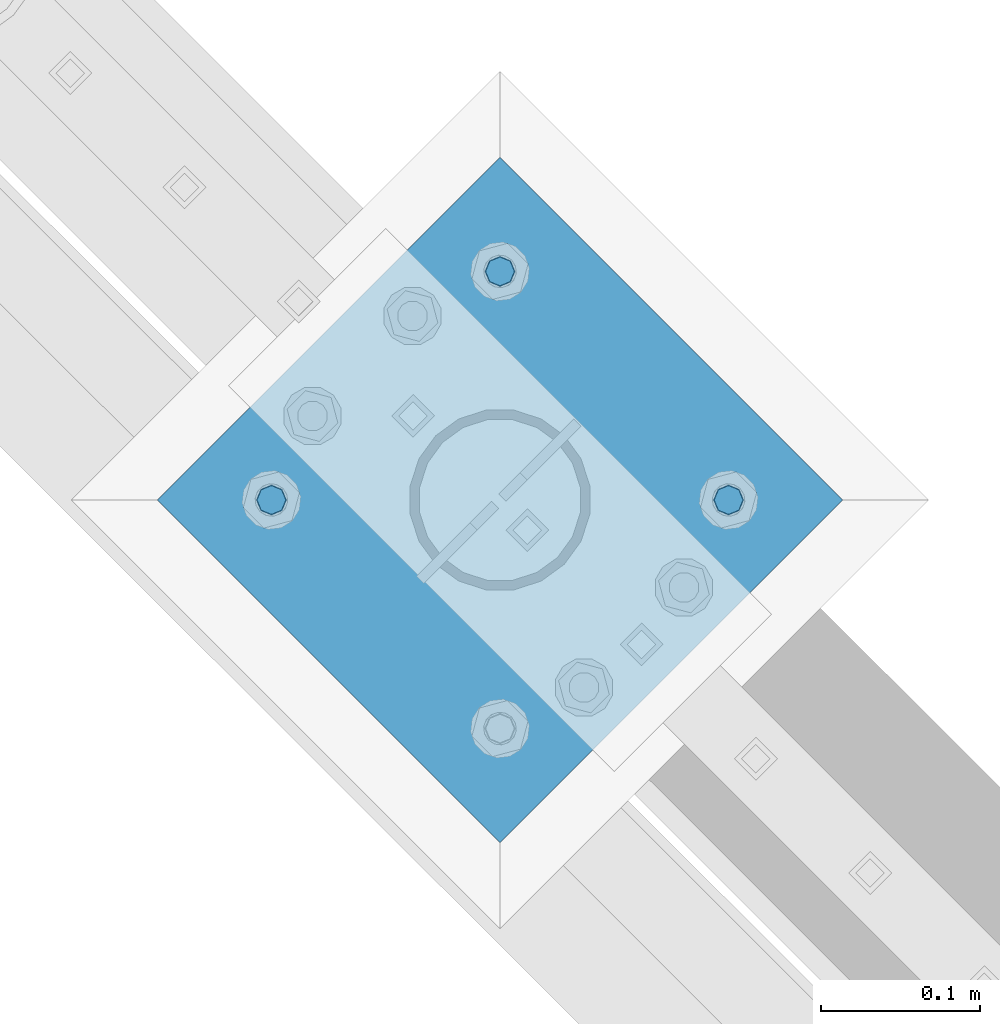
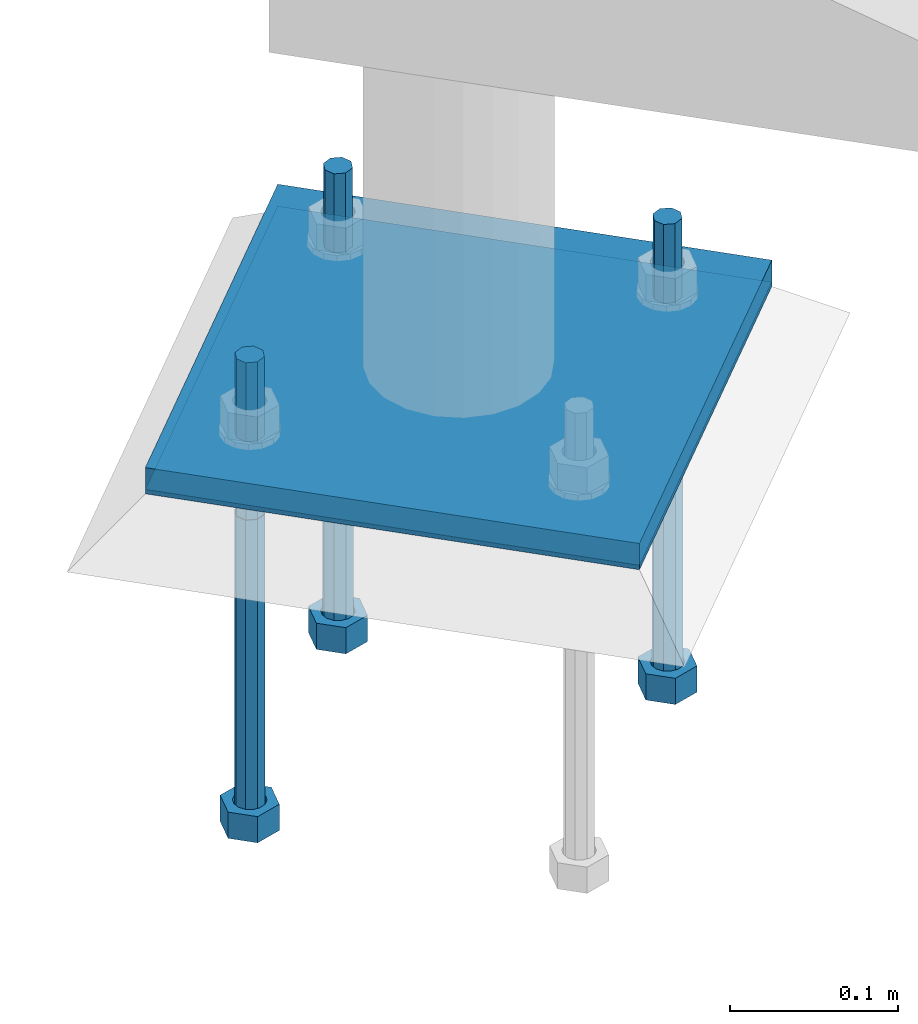
# One storey, part 528 of 975: 5 beams.
"""IFC2X3 building model written with IfcOpenShell, lengths in millimetres."""

from ifc_helpers import new_model, si_unit, frame, origin_with_axes, place, context, subcontext, project, spatial, faceted_brep, material, type_object, element, save


model = new_model("IFC2X3")

# Units and contexts
model_context = context("Model", 3, precision=1e-05, world=origin_with_axes())
body_context = subcontext(model_context, "Body", "Model", "MODEL_VIEW")
ifc_project = project(units=[si_unit("LENGTHUNIT", "METRE", prefix="MILLI"), si_unit("AREAUNIT", "SQUARE_METRE"), si_unit("VOLUMEUNIT", "CUBIC_METRE"), si_unit("MASSUNIT", "GRAM", prefix="KILO"), si_unit("TIMEUNIT", "SECOND"), si_unit("PLANEANGLEUNIT", "RADIAN"), si_unit("SOLIDANGLEUNIT", "STERADIAN"), si_unit("THERMODYNAMICTEMPERATUREUNIT", "DEGREE_CELSIUS"), si_unit("LUMINOUSINTENSITYUNIT", "LUMEN")], contexts=[model_context])

# Site, building, storey
site_placement = place(None, origin_with_axes())
site = spatial("IfcSite", under=ifc_project, at=site_placement, CompositionType="ELEMENT")
building_placement = place(site_placement, origin_with_axes())
building = spatial("IfcBuilding", under=site, at=building_placement, Name="Undefined", CompositionType="ELEMENT")
storey_placement = place(building_placement, origin_with_axes())
storey = spatial("IfcBuildingStorey", under=building, at=storey_placement, Name="Undefined", CompositionType="ELEMENT", Elevation=0.0)

# Beams
ifc_material_1 = material(Name="STEEL/A36")
beam_type_1 = type_object("IfcBeamType", PredefinedType="NOTDEFINED")
beam_1_placement = place(storey_placement, frame((30438.9119265474, 17981.7994265474, -257.175000000002), z_axis=(-0.707106781186601, 0.707106781186494, 2.36468622460961e-14), x_axis=(0.707106781186548, 0.707106781186548, 0.0)))
element("IfcBeam", 1, at=beam_1_placement, inside=storey, type_object=beam_type_1, material=ifc_material_1, Name="PLATE", context=body_context, shape_type="Brep", body=[
    faceted_brep([(0.0, 9.52499999999964, -152.4), (0.0, 9.52499999999964, 152.4), (304.799999999152, 9.52499999999964, 152.4), (304.799999999152, 9.52499999999964, -152.4), (0.0, -9.52499999999964, 152.4), (304.799999999152, -9.52499999999964, 152.4), (0.0, -9.52499999999964, -152.4), (304.799999999152, -9.52499999999964, -152.4)], [[[0, 1, 2, 3]], [[1, 4, 5, 2]], [[4, 6, 7, 5]], [[6, 0, 3, 7]], [[5, 7, 3, 2]], [[6, 4, 1, 0]]]),
])
ifc_material_2 = material(Name="STEEL/F1554-36")
beam_type_2 = type_object("IfcBeamType", PredefinedType="NOTDEFINED")
beam_2_placement = place(storey_placement, frame((30402.9909053001, 18089.562501079, -304.799999999999), z_axis=(0.707106781186548, 0.707106781186548, 0.0), x_axis=(0.0, 0.0, -1.0)))
element("IfcBeam", 2, at=beam_2_placement, inside=storey, type_object=beam_type_2, material=ifc_material_2, Name="HEADED_ANCHOR_BOLT", context=body_context, shape_type="Brep", body=[
    faceted_brep([(209.543749999999, 9.13000011446275, -15.8100004196049), (209.543749999999, 18.2600002288382, -4.72937244921923e-11), (228.593749999998, 18.2600002288382, -4.72937244921923e-11), (228.593749999998, 9.13000011446275, -15.8100004196049), (209.543749999999, -9.13000011438271, -15.8100004195576), (228.593749999998, -9.13000011438271, -15.8100004195576), (209.543749999999, -18.2600002288382, 4.72937244921923e-11), (228.593749999998, -18.2600002288382, 4.72937244921923e-11), (209.543749999999, -9.13000011446275, 15.8100004196049), (228.593749999998, -9.13000011446275, 15.8100004196049), (209.543749999999, 9.13000011438271, 15.8100004195576), (228.593749999998, 9.13000011438271, 15.8100004195576), (209.543749999999, -4.4776800552936, 9.29799844178979), (209.543749999999, -8.068500660469, 6.43441456491473), (209.543749999999, -10.0612557561763, 2.2964159705416), (209.543749999999, -10.0612557561617, -2.29641597048976), (209.543749999999, -8.0685006604399, -6.4344145648729), (209.543749999999, -4.47768005524995, -9.29799844176705), (209.543749999999, 2.91038304567337e-11, -10.3199996948015), (209.543749999999, 4.4776800552936, -9.29799844178979), (209.543749999999, 8.068500660469, -6.43441456491473), (209.543749999999, 10.0612557561763, -2.2964159705416), (209.543749999999, 10.0612557561617, 2.29641597048976), (209.543749999999, 8.0685006604399, 6.4344145648729), (209.543749999999, 4.47768005524995, 9.29799844176705), (209.543749999999, -2.91038304567337e-11, 10.3199996948015), (228.593749999998, 2.91038304567337e-11, -10.3199996948015), (228.593749999998, 4.4776800552936, -9.29799844178979), (228.593749999998, 8.068500660469, -6.43441456491473), (228.593749999998, 10.0612557561763, -2.2964159705416), (228.593749999998, 10.0612557561617, 2.29641597048976), (228.593749999998, 8.0685006604399, 6.4344145648729), (228.593749999998, 4.47768005524995, 9.29799844176705), (228.593749999998, -2.91038304567337e-11, 10.3199996948015), (228.593749999998, -4.4776800552936, 9.29799844178979), (228.593749999998, -8.068500660469, 6.43441456491473), (228.593749999998, -10.0612557561763, 2.2964159705416), (228.593749999998, -10.0612557561617, -2.29641597048976), (228.593749999998, -8.0685006604399, -6.4344145648729), (228.593749999998, -4.47768005524995, -9.29799844176705), (0.0, -6.73519209080223, 6.73519209080186), (0.0, -9.52499999999964, 0.0), (228.6, -9.52500000000146, 0.0), (228.6, -6.73519209080405, 6.73519209080223), (-9.87109982941227e-13, -1.20792265079217e-13, 9.52499961853027), (228.6, 0.0, 9.52499999999964), (0.0, 6.73519209080223, 6.73519209080186), (228.6, 6.73519209080405, 6.73519209080223), (0.0, 9.52499999999964, 0.0), (228.6, 9.52500000000146, 0.0), (0.0, 6.73519209080223, -6.73519209080186), (228.6, 6.73519209080405, -6.73519209080223), (2.95075507493764e-12, -1.20792265079217e-13, -9.52499961853027), (228.6, 0.0, -9.52499999999964), (-114.297914995421, -6.36396103067818, 6.36396103068091), (-114.297914995421, -2.18278728425503e-11, 8.99999999997999), (-114.297914995421, 6.36396103064908, 6.36396103064817), (-114.297914995421, 8.99999999997817, -2.27373675443232e-11), (-114.297914995421, 6.36396103067818, -6.36396103068091), (-114.297914995421, 2.18278728425503e-11, -8.99999999997999), (-114.297914995421, -6.36396103064908, -6.36396103064817), (-114.297914995421, -8.99999999997817, 2.27373675443232e-11), (0.0149743263646087, 6.36396103067818, -6.36396103067909), (0.0149743263646087, 0.0, -9.0), (0.0149743263646087, -6.36396103067818, -6.36396103067909), (0.0149743263987148, -8.9999995411581, -1.00796984270346e-06), (0.0149743263646087, -6.36396103067818, 6.36396103067909), (0.0149743263646087, 0.0, 9.0), (0.0149743263646087, 6.36396103067818, 6.36396103067909), (0.0149743263987148, 9.0000004588419, -1.00796984270346e-06), (0.0, -6.73519209080223, -6.73519209080186), (228.6, -6.73519209080405, -6.73519209080223)], [[[0, 1, 2, 3]], [[4, 0, 3, 5]], [[6, 4, 5, 7]], [[8, 6, 7, 9]], [[10, 8, 9, 11]], [[8, 10, 1, 0, 4, 6], [12, 13, 14, 15, 16, 17, 18, 19, 20, 21, 22, 23, 24, 25]], [[19, 18, 26, 27]], [[20, 19, 27, 28]], [[21, 20, 28, 29]], [[22, 21, 29, 30]], [[23, 22, 30, 31]], [[24, 23, 31, 32]], [[25, 24, 32, 33]], [[12, 25, 33, 34]], [[13, 12, 34, 35]], [[14, 13, 35, 36]], [[15, 14, 36, 37]], [[16, 15, 37, 38]], [[17, 16, 38, 39]], [[18, 17, 39, 26]], [[3, 2, 11, 9, 7, 5], [31, 30, 29, 28, 27, 26, 39, 38, 37, 36, 35, 34, 33, 32]], [[1, 10, 11, 2]], [[40, 41, 42, 43]], [[44, 40, 43, 45]], [[46, 44, 45, 47]], [[48, 46, 47, 49]], [[50, 48, 49, 51]], [[52, 50, 51, 53]], [[54, 55, 56, 57, 58, 59, 60, 61]], [[59, 58, 62, 63]], [[60, 59, 63, 64]], [[61, 60, 64, 65]], [[54, 61, 65, 66]], [[55, 54, 66, 67]], [[56, 55, 67, 68]], [[57, 56, 68, 69]], [[58, 57, 69, 62]], [[40, 44, 46, 48, 50, 52, 70, 41], [68, 67, 66, 65, 64, 63, 62, 69]], [[41, 70, 71, 42]], [[53, 51, 49, 47, 45, 43, 42, 71]], [[70, 52, 53, 71]]]),
])
beam_3_placement = place(storey_placement, frame((30546.675001079, 18233.2465968578, -304.799999999999), z_axis=(0.707106781186548, 0.707106781186548, 0.0), x_axis=(0.0, 0.0, -1.0)))
element("IfcBeam", 3, at=beam_3_placement, inside=storey, type_object=beam_type_2, material=ifc_material_2, Name="HEADED_ANCHOR_BOLT", context=body_context, shape_type="Brep", body=[
    faceted_brep([(209.543749999999, 9.13000011446275, -15.8100004196049), (209.543749999999, 18.2600002288382, -4.72937244921923e-11), (228.593749999998, 18.2600002288382, -4.72937244921923e-11), (228.593749999998, 9.13000011446275, -15.8100004196049), (209.543749999999, -9.13000011438271, -15.8100004195576), (228.593749999998, -9.13000011438271, -15.8100004195576), (209.543749999999, -18.2600002288382, 4.72937244921923e-11), (228.593749999998, -18.2600002288382, 4.72937244921923e-11), (209.543749999999, -9.13000011446275, 15.8100004196049), (228.593749999998, -9.13000011446275, 15.8100004196049), (209.543749999999, 9.13000011438271, 15.8100004195576), (228.593749999998, 9.13000011438271, 15.8100004195576), (209.543749999999, -4.4776800552936, 9.29799844178979), (209.543749999999, -8.068500660469, 6.43441456491473), (209.543749999999, -10.0612557561763, 2.2964159705416), (209.543749999999, -10.0612557561617, -2.29641597048976), (209.543749999999, -8.0685006604399, -6.4344145648729), (209.543749999999, -4.47768005524995, -9.29799844176705), (209.543749999999, 2.91038304567337e-11, -10.3199996948015), (209.543749999999, 4.4776800552936, -9.29799844178979), (209.543749999999, 8.068500660469, -6.43441456491473), (209.543749999999, 10.0612557561763, -2.2964159705416), (209.543749999999, 10.0612557561617, 2.29641597048976), (209.543749999999, 8.0685006604399, 6.4344145648729), (209.543749999999, 4.47768005524995, 9.29799844176705), (209.543749999999, -2.91038304567337e-11, 10.3199996948015), (228.593749999998, 2.91038304567337e-11, -10.3199996948015), (228.593749999998, 4.4776800552936, -9.29799844178979), (228.593749999998, 8.068500660469, -6.43441456491473), (228.593749999998, 10.0612557561763, -2.2964159705416), (228.593749999998, 10.0612557561617, 2.29641597048976), (228.593749999998, 8.0685006604399, 6.4344145648729), (228.593749999998, 4.47768005524995, 9.29799844176705), (228.593749999998, -2.91038304567337e-11, 10.3199996948015), (228.593749999998, -4.4776800552936, 9.29799844178979), (228.593749999998, -8.068500660469, 6.43441456491473), (228.593749999998, -10.0612557561763, 2.2964159705416), (228.593749999998, -10.0612557561617, -2.29641597048976), (228.593749999998, -8.0685006604399, -6.4344145648729), (228.593749999998, -4.47768005524995, -9.29799844176705), (0.0, -6.73519209080223, 6.73519209080186), (0.0, -9.52499999999964, 0.0), (228.6, -9.52500000000146, 0.0), (228.6, -6.73519209080405, 6.73519209080223), (-9.87109982941227e-13, -1.20792265079217e-13, 9.52499961853027), (228.6, 0.0, 9.52499999999964), (0.0, 6.73519209080223, 6.73519209080186), (228.6, 6.73519209080405, 6.73519209080223), (0.0, 9.52499999999964, 0.0), (228.6, 9.52500000000146, 0.0), (0.0, 6.73519209080223, -6.73519209080186), (228.6, 6.73519209080405, -6.73519209080223), (2.95075507493764e-12, -1.20792265079217e-13, -9.52499961853027), (228.6, 0.0, -9.52499999999964), (-114.297914995421, -6.36396103067818, 6.36396103068091), (-114.297914995421, -2.18278728425503e-11, 8.99999999997999), (-114.297914995421, 6.36396103064908, 6.36396103064817), (-114.297914995421, 8.99999999997817, -2.27373675443232e-11), (-114.297914995421, 6.36396103067818, -6.36396103068091), (-114.297914995421, 2.18278728425503e-11, -8.99999999997999), (-114.297914995421, -6.36396103064908, -6.36396103064817), (-114.297914995421, -8.99999999997817, 2.27373675443232e-11), (0.0149743263646087, 6.36396103067818, -6.36396103067909), (0.0149743263646087, 0.0, -9.0), (0.0149743263646087, -6.36396103067818, -6.36396103067909), (0.0149743263987148, -8.9999995411581, -1.00796984270346e-06), (0.0149743263646087, -6.36396103067818, 6.36396103067909), (0.0149743263646087, 0.0, 9.0), (0.0149743263646087, 6.36396103067818, 6.36396103067909), (0.0149743263987148, 9.0000004588419, -1.00796984270346e-06), (0.0, -6.73519209080223, -6.73519209080186), (228.6, -6.73519209080405, -6.73519209080223)], [[[0, 1, 2, 3]], [[4, 0, 3, 5]], [[6, 4, 5, 7]], [[8, 6, 7, 9]], [[10, 8, 9, 11]], [[8, 10, 1, 0, 4, 6], [12, 13, 14, 15, 16, 17, 18, 19, 20, 21, 22, 23, 24, 25]], [[19, 18, 26, 27]], [[20, 19, 27, 28]], [[21, 20, 28, 29]], [[22, 21, 29, 30]], [[23, 22, 30, 31]], [[24, 23, 31, 32]], [[25, 24, 32, 33]], [[12, 25, 33, 34]], [[13, 12, 34, 35]], [[14, 13, 35, 36]], [[15, 14, 36, 37]], [[16, 15, 37, 38]], [[17, 16, 38, 39]], [[18, 17, 39, 26]], [[3, 2, 11, 9, 7, 5], [31, 30, 29, 28, 27, 26, 39, 38, 37, 36, 35, 34, 33, 32]], [[1, 10, 11, 2]], [[40, 41, 42, 43]], [[44, 40, 43, 45]], [[46, 44, 45, 47]], [[48, 46, 47, 49]], [[50, 48, 49, 51]], [[52, 50, 51, 53]], [[54, 55, 56, 57, 58, 59, 60, 61]], [[59, 58, 62, 63]], [[60, 59, 63, 64]], [[61, 60, 64, 65]], [[54, 61, 65, 66]], [[55, 54, 66, 67]], [[56, 55, 67, 68]], [[57, 56, 68, 69]], [[58, 57, 69, 62]], [[40, 44, 46, 48, 50, 52, 70, 41], [68, 67, 66, 65, 64, 63, 62, 69]], [[41, 70, 71, 42]], [[53, 51, 49, 47, 45, 43, 42, 71]], [[70, 52, 53, 71]]]),
])
beam_4_placement = place(storey_placement, frame((30690.3590968578, 18089.562501079, -304.799999999999), z_axis=(0.707106781186548, 0.707106781186548, 0.0), x_axis=(0.0, 0.0, -1.0)))
element("IfcBeam", 4, at=beam_4_placement, inside=storey, type_object=beam_type_2, material=ifc_material_2, Name="HEADED_ANCHOR_BOLT", context=body_context, shape_type="Brep", body=[
    faceted_brep([(209.543749999999, -9.13000011446275, 15.8100004196049), (209.543749999999, -18.2600002288382, 4.72937244921923e-11), (228.593749999998, -18.2600002288382, 4.72937244921923e-11), (228.593749999998, -9.13000011446275, 15.8100004196049), (209.543749999999, 9.13000011438271, 15.8100004195576), (228.593749999998, 9.13000011438271, 15.8100004195576), (209.543749999999, 18.2600002288382, -4.72937244921923e-11), (228.593749999998, 18.2600002288382, -4.72937244921923e-11), (209.543749999999, 9.13000011446275, -15.8100004196049), (228.593749999998, 9.13000011446275, -15.8100004196049), (209.543749999999, -9.13000011438271, -15.8100004195576), (228.593749999998, -9.13000011438271, -15.8100004195576), (209.543749999999, -4.4776800552936, 9.29799844178979), (209.543749999999, -8.068500660469, 6.43441456491473), (209.543749999999, -10.0612557561763, 2.2964159705416), (209.543749999999, -10.0612557561617, -2.29641597048976), (209.543749999999, -8.0685006604399, -6.4344145648729), (209.543749999999, -4.47768005524995, -9.29799844176705), (209.543749999999, 2.91038304567337e-11, -10.3199996948015), (209.543749999999, 4.4776800552936, -9.29799844178979), (209.543749999999, 8.068500660469, -6.43441456491473), (209.543749999999, 10.0612557561763, -2.2964159705416), (209.543749999999, 10.0612557561617, 2.29641597048976), (209.543749999999, 8.0685006604399, 6.4344145648729), (209.543749999999, 4.47768005524995, 9.29799844176705), (209.543749999999, -2.91038304567337e-11, 10.3199996948015), (228.593749999998, -2.91038304567337e-11, 10.3199996948015), (228.593749999998, -4.4776800552936, 9.29799844178979), (228.593749999998, -8.068500660469, 6.43441456491473), (228.593749999998, -10.0612557561763, 2.2964159705416), (228.593749999998, -10.0612557561617, -2.29641597048976), (228.593749999998, -8.0685006604399, -6.4344145648729), (228.593749999998, -4.47768005524995, -9.29799844176705), (228.593749999998, 2.91038304567337e-11, -10.3199996948015), (228.593749999998, 4.4776800552936, -9.29799844178979), (228.593749999998, 8.068500660469, -6.43441456491473), (228.593749999998, 10.0612557561763, -2.2964159705416), (228.593749999998, 10.0612557561617, 2.29641597048976), (228.593749999998, 8.0685006604399, 6.4344145648729), (228.593749999998, 4.47768005524995, 9.29799844176705), (0.0, -6.73519209080223, 6.73519209080186), (0.0, -9.52499999999964, 0.0), (228.6, -9.52500000000146, 0.0), (228.6, -6.73519209080405, 6.73519209080223), (-9.87109982941227e-13, -1.20792265079217e-13, 9.52499961853027), (228.6, 0.0, 9.52499999999964), (0.0, 6.73519209080223, 6.73519209080186), (228.6, 6.73519209080405, 6.73519209080223), (0.0, 9.52499999999964, 0.0), (228.6, 9.52500000000146, 0.0), (0.0, 6.73519209080223, -6.73519209080186), (228.6, 6.73519209080405, -6.73519209080223), (2.95075507493764e-12, -1.20792265079217e-13, -9.52499961853027), (228.6, 0.0, -9.52499999999964), (-114.297914995421, -6.36396103067818, 6.36396103068091), (-114.297914995421, -2.18278728425503e-11, 8.99999999997999), (-114.297914995421, 6.36396103064908, 6.36396103064817), (-114.297914995421, 8.99999999997817, -2.27373675443232e-11), (-114.297914995421, 6.36396103067818, -6.36396103068091), (-114.297914995421, 2.18278728425503e-11, -8.99999999997999), (-114.297914995421, -6.36396103064908, -6.36396103064817), (-114.297914995421, -8.99999999997817, 2.27373675443232e-11), (0.0149743263646087, 6.36396103067818, -6.36396103067909), (0.0149743263646087, 0.0, -9.0), (0.0149743263646087, -6.36396103067818, -6.36396103067909), (0.0149743263987148, -8.9999995411581, -1.00796984270346e-06), (0.0149743263646087, -6.36396103067818, 6.36396103067909), (0.0149743263646087, 0.0, 9.0), (0.0149743263646087, 6.36396103067818, 6.36396103067909), (0.0149743263987148, 9.0000004588419, -1.00796984270346e-06), (0.0, -6.73519209080223, -6.73519209080186), (228.6, -6.73519209080405, -6.73519209080223)], [[[0, 1, 2, 3]], [[4, 0, 3, 5]], [[6, 4, 5, 7]], [[8, 6, 7, 9]], [[10, 8, 9, 11]], [[0, 4, 6, 8, 10, 1], [12, 13, 14, 15, 16, 17, 18, 19, 20, 21, 22, 23, 24, 25]], [[12, 25, 26, 27]], [[13, 12, 27, 28]], [[14, 13, 28, 29]], [[15, 14, 29, 30]], [[16, 15, 30, 31]], [[17, 16, 31, 32]], [[18, 17, 32, 33]], [[19, 18, 33, 34]], [[20, 19, 34, 35]], [[21, 20, 35, 36]], [[22, 21, 36, 37]], [[23, 22, 37, 38]], [[24, 23, 38, 39]], [[25, 24, 39, 26]], [[9, 7, 5, 3, 2, 11], [38, 37, 36, 35, 34, 33, 32, 31, 30, 29, 28, 27, 26, 39]], [[1, 10, 11, 2]], [[40, 41, 42, 43]], [[44, 40, 43, 45]], [[46, 44, 45, 47]], [[48, 46, 47, 49]], [[50, 48, 49, 51]], [[52, 50, 51, 53]], [[54, 55, 56, 57, 58, 59, 60, 61]], [[59, 58, 62, 63]], [[60, 59, 63, 64]], [[61, 60, 64, 65]], [[54, 61, 65, 66]], [[55, 54, 66, 67]], [[56, 55, 67, 68]], [[57, 56, 68, 69]], [[58, 57, 69, 62]], [[40, 44, 46, 48, 50, 52, 70, 41], [68, 67, 66, 65, 64, 63, 62, 69]], [[41, 70, 71, 42]], [[53, 51, 49, 47, 45, 43, 42, 71]], [[70, 52, 53, 71]]]),
])
beam_type_3 = type_object("IfcBeamType", PredefinedType="NOTDEFINED")
beam_5_placement = place(storey_placement, frame((30438.9119265474, 17981.7994265474, -265.112500000001), z_axis=(-0.707106781186601, 0.707106781186494, 2.36468622460961e-14), x_axis=(0.707106781186548, 0.707106781186548, 0.0)))
element("IfcBeam", 5, at=beam_5_placement, inside=storey, type_object=beam_type_3, material=ifc_material_1, Name="TEMPLATE", context=body_context, shape_type="Brep", body=[
    faceted_brep([(0.0, 1.58750000000009, -152.4), (0.0, 1.58750000000009, 152.4), (304.799999999153, 1.58750000000001, 152.400000000001), (304.799999999153, 1.58750000000001, -152.400000000001), (0.0, -1.58750000000009, 152.4), (304.799999999153, -1.58750000000001, 152.400000000001), (0.0, -1.58750000000009, -152.4), (304.799999999153, -1.58750000000001, -152.400000000001)], [[[0, 1, 2, 3]], [[1, 4, 5, 2]], [[4, 6, 7, 5]], [[6, 0, 3, 7]], [[5, 7, 3, 2]], [[6, 4, 1, 0]]]),
])

save(model, "model.ifc")
